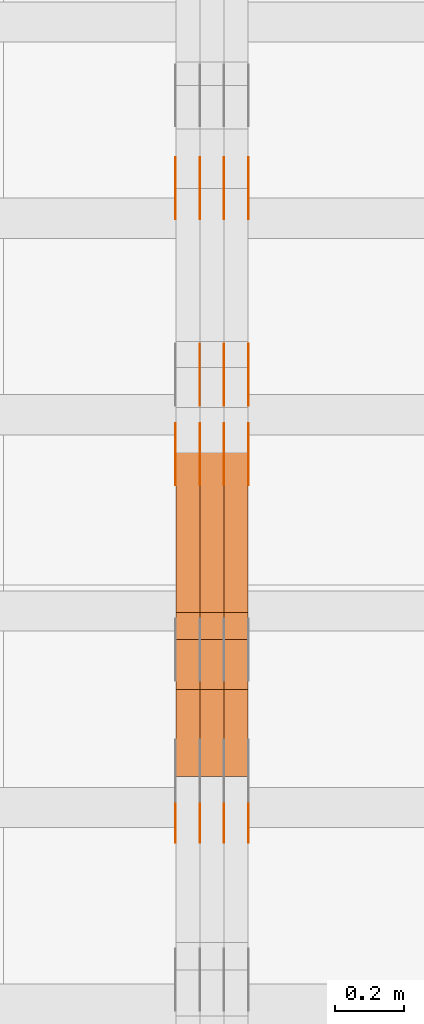
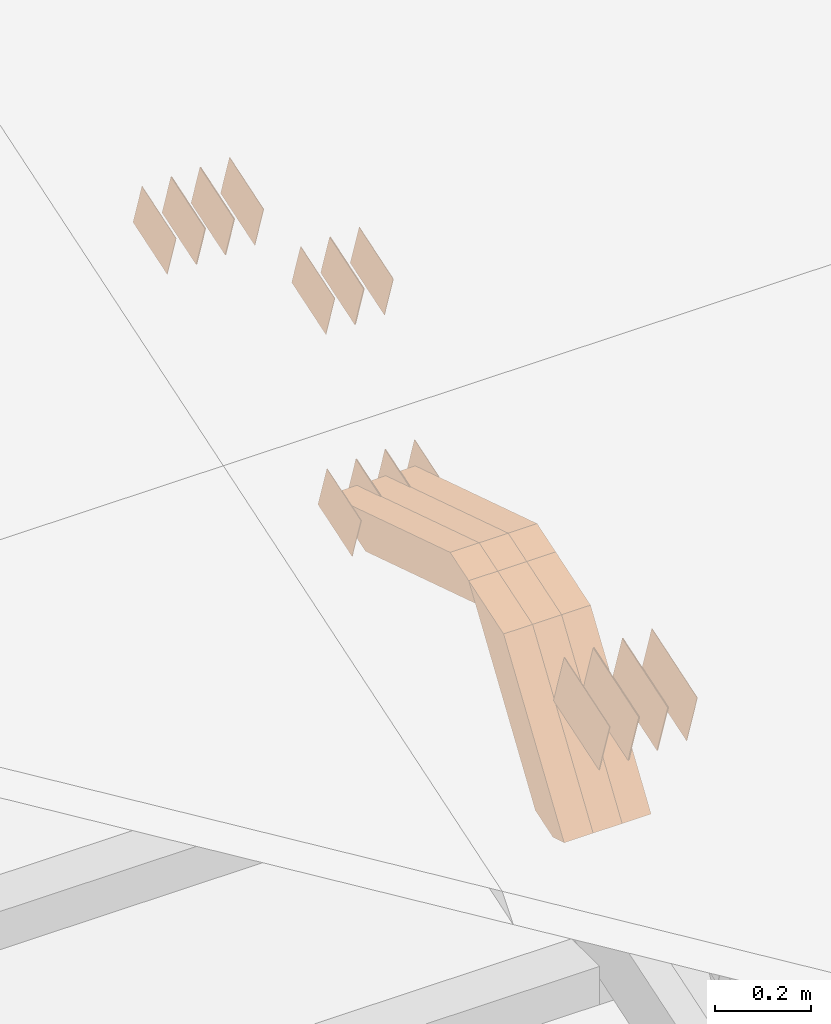
# One storey, part 110 of 385: 28 proxies.
"""IFC2X3 building model written with IfcOpenShell, lengths in millimetres."""

import ifcopenshell
import ifcopenshell.guid

model = None  # the IFC model being written
_history = None  # IfcOwnerHistory: only IFC2X3 demands one
_inside = {}  # id of a spatial element -> (the spatial element, [elements in it])
_under = {}  # id of a project, library or spatial element -> (it, [spatial elements below it])
_declared = {}  # id of a project -> (the project, [libraries it declares])
_typed = {}  # id of a type object -> (the type object, [elements of that type])
_made_of = {}  # id of a material, layer set ... -> (it, [elements and type objects made of it])


def new_model(schema):
    """Start an empty IFC model of exactly this schema.

    Asked for "IFC4X3", IfcOpenShell would pick the latest addendum, in which some entities
    have other attributes; the version numbers below select the first issue.
    IFC2X3 requires an IfcOwnerHistory on every rooted entity: one is made here for all.
    """
    global model, _history
    if schema == "IFC4X3":
        model = ifcopenshell.file(schema_version=(4, 3, 0, 0))
    else:
        model = ifcopenshell.file(schema=schema)
    _inside.clear()
    _under.clear()
    _declared.clear()
    _typed.clear()
    _made_of.clear()
    _history = None
    if model.schema == "IFC2X3":
        org = make("IfcOrganization", Name="unknown")
        user = make(
            "IfcPersonAndOrganization",
            ThePerson=make("IfcPerson", FamilyName="unknown"),
            TheOrganization=org,
        )
        app = make(
            "IfcApplication",
            ApplicationDeveloper=org,
            Version="unknown",
            ApplicationFullName="unknown",
            ApplicationIdentifier="unknown",
        )
        _history = make(
            "IfcOwnerHistory",
            OwningUser=user,
            OwningApplication=app,
            ChangeAction="ADDED",
            CreationDate=0,
        )
    return model


def make(cls, **values):
    """One entity of the class cls with the attributes given. An attribute that is None is left unset."""
    return model.create_entity(
        cls, **{name: value for name, value in values.items() if value is not None}
    )


def entity(cls, *values):
    """Any entity or typed value of the class cls, its attributes in the order of the schema. None: left unset."""
    e = model.create_entity(cls)
    for i, value in enumerate(values):
        if value is not None:
            e[i] = value
    return e


def rooted(cls, **values):
    """An entity with a GlobalId (a new one), such as an element, a storey or a relation."""
    return make(cls, GlobalId=ifcopenshell.guid.new(), OwnerHistory=_history, **values)


def si_unit(unit_type, name, prefix=None):
    """IfcSIUnit, for example si_unit("LENGTHUNIT", "METRE", prefix="MILLI")."""
    return make("IfcSIUnit", UnitType=unit_type, Prefix=prefix, Name=name)


def converted_unit(unit_type, name, factor, base, dimensions=None, offset=None):
    """IfcConversionBasedUnit, such as the inch: factor (a typed value) times the base unit."""
    return make(
        "IfcConversionBasedUnit"
        if offset is None
        else "IfcConversionBasedUnitWithOffset",
        ConversionOffset=offset,
        Dimensions=None
        if dimensions is None
        else entity("IfcDimensionalExponents", *dimensions),
        UnitType=unit_type,
        Name=name,
        ConversionFactor=make(
            "IfcMeasureWithUnit", ValueComponent=factor, UnitComponent=base
        ),
    )


def derived_unit(unit_type, elements):
    """IfcDerivedUnit: a product of units, each with its exponent."""
    return make(
        "IfcDerivedUnit",
        Elements=[
            make("IfcDerivedUnitElement", Unit=unit, Exponent=power)
            for unit, power in elements
        ],
        UnitType=unit_type,
    )


def assignment(units):
    """IfcUnitAssignment: the units of a project."""
    return None if units is None else make("IfcUnitAssignment", Units=units)


def point(xyz):
    """IfcCartesianPoint."""
    return None if xyz is None else make("IfcCartesianPoint", Coordinates=xyz)


def direction(xyz):
    """IfcDirection."""
    return None if xyz is None else make("IfcDirection", DirectionRatios=xyz)


def frame(location, z_axis=None, x_axis=None):
    """IfcAxis2Placement3D, a coordinate frame: its origin and axes. An axis left out is left unset."""
    return make(
        "IfcAxis2Placement3D",
        Location=point(location),
        Axis=direction(z_axis),
        RefDirection=direction(x_axis),
    )


def origin():
    """The frame at (0, 0, 0) with its axes left unset."""
    return frame((0.0, 0.0, 0.0))


def place(relative_to, where):
    """IfcLocalPlacement: puts the frame where relative to a parent placement (None: the world)."""
    return make(
        "IfcLocalPlacement", PlacementRelTo=relative_to, RelativePlacement=where
    )


def context(
    kind, dimensions, precision=None, world=None, true_north=None, identifier=None
):
    """IfcGeometricRepresentationContext, for example the 3D "Model" context."""
    return make(
        "IfcGeometricRepresentationContext",
        ContextIdentifier=identifier,
        ContextType=kind,
        CoordinateSpaceDimension=dimensions,
        Precision=precision,
        WorldCoordinateSystem=world,
        TrueNorth=true_north,
    )


def subcontext(parent, identifier, kind, view, scale=None):
    """IfcGeometricRepresentationSubContext, for example "Body" below "Model"."""
    return make(
        "IfcGeometricRepresentationSubContext",
        ContextIdentifier=identifier,
        ContextType=kind,
        ParentContext=parent,
        TargetScale=scale,
        TargetView=view,
    )


def project(units=None, contexts=None):
    """IfcProject with its units and contexts."""
    return rooted(
        "IfcProject",
        Name="project",
        RepresentationContexts=contexts,
        UnitsInContext=assignment(units),
    )


def spatial(cls, under=None, at=None, **own):
    """A site, building, storey or space (cls), placed at a placement, below another one or the project."""
    s = rooted(cls, ObjectPlacement=at, **own)
    if under is not None:
        _under.setdefault(under.id(), (under, []))[1].append(s)
    return s


def polyline(points):
    """IfcPolyline through the points."""
    return make("IfcPolyline", Points=[point(p) for p in points])


def outline(outer, holes=None, kind="AREA"):
    """IfcArbitraryClosedProfileDef: a profile drawn as a closed curve; with holes, ...WithVoids."""
    if holes is None:
        return make("IfcArbitraryClosedProfileDef", ProfileType=kind, OuterCurve=outer)
    return make(
        "IfcArbitraryProfileDefWithVoids",
        ProfileType=kind,
        OuterCurve=outer,
        InnerCurves=holes,
    )


def extrude(swept, where, along, depth):
    """IfcExtrudedAreaSolid: the profile swept, set in the frame where, extruded along a direction by depth."""
    return make(
        "IfcExtrudedAreaSolid",
        SweptArea=swept,
        Position=where,
        ExtrudedDirection=direction(along),
        Depth=depth,
    )


def shape(context_of_items, identifier, shape_type, items):
    """IfcShapeRepresentation: the items that make up one representation, for example the "Body"."""
    return make(
        "IfcShapeRepresentation",
        ContextOfItems=context_of_items,
        RepresentationIdentifier=identifier,
        RepresentationType=shape_type,
        Items=items,
    )


def source(mapping_origin, context_of_items, identifier, shape_type, items):
    """IfcRepresentationMap: a shape defined once, which mapped items show again and again."""
    return make(
        "IfcRepresentationMap",
        MappingOrigin=mapping_origin,
        MappedRepresentation=shape(context_of_items, identifier, shape_type, items),
    )


def transform(
    local_origin,
    x_axis=None,
    y_axis=None,
    z_axis=None,
    scale=None,
    scale2=None,
    scale3=None,
    uniform=True,
):
    """IfcCartesianTransformationOperator3D, or its non-uniform kind. x_axis, y_axis, z_axis: its Axis1, 2, 3."""
    if uniform:
        return make(
            "IfcCartesianTransformationOperator3D",
            Axis1=direction(x_axis),
            Axis2=direction(y_axis),
            LocalOrigin=point(local_origin),
            Scale=scale,
            Axis3=direction(z_axis),
        )
    return make(
        "IfcCartesianTransformationOperator3DnonUniform",
        Axis1=direction(x_axis),
        Axis2=direction(y_axis),
        LocalOrigin=point(local_origin),
        Scale=scale,
        Axis3=direction(z_axis),
        Scale2=scale2,
        Scale3=scale3,
    )


def mapped(mapping_source, mapping_target):
    """IfcMappedItem: shows the shape of a source again, moved by a transform."""
    return make(
        "IfcMappedItem", MappingSource=mapping_source, MappingTarget=mapping_target
    )


def material(Name=None, Category=None):
    """IfcMaterial."""
    return make("IfcMaterial", Name=Name, Category=Category)


def made_of(thing, what):
    """Note that an element or type object is made of a material, layer set ...; save() writes the relation."""
    if what is not None:
        _made_of.setdefault(what.id(), (what, []))[1].append(thing)
    return thing


def type_object(cls, material=None, **own):
    """A type object (cls), such as IfcWallType, which elements share."""
    return made_of(rooted(cls, **own), material)


def type_shapes(of_type, sources):
    """Give a type object the sources (RepresentationMaps) that its elements show as mapped items."""
    of_type.RepresentationMaps = sources


def element(
    cls,
    number,
    at=None,
    inside=None,
    cuts=None,
    type_object=None,
    material=None,
    context=None,
    identifier="Body",
    shape_type=None,
    held_by="IfcProductDefinitionShape",
    body=None,
    shapes=None,
    **own,
):
    """One element of the class cls, such as IfcWall. Its Tag is "e" and its number.

    at: its placement. inside: the storey or other place that contains it. cuts: it is an
    opening in that element (IfcRelVoidsElement). A single representation is given by context,
    identifier, shape_type and body (its items); several are given by shapes. held_by: the class
    of the entity that holds the representations. save() writes the other relations.
    """
    e = rooted(cls, Tag="e%d" % number, ObjectPlacement=at, **own)
    if body is not None:
        shapes = [shape(context, identifier, shape_type, body)]
    if shapes is not None:
        e.Representation = make(held_by, Representations=shapes)
    if inside is not None:
        _inside.setdefault(inside.id(), (inside, []))[1].append(e)
    if cuts is not None:
        rooted(
            "IfcRelVoidsElement", RelatingBuildingElement=cuts, RelatedOpeningElement=e
        )
    if type_object is not None:
        _typed.setdefault(type_object.id(), (type_object, []))[1].append(e)
    return made_of(e, material)


def aggregate(whole, parts):
    """IfcRelAggregates: a whole, such as a stair, and the parts it consists of."""
    return rooted("IfcRelAggregates", RelatingObject=whole, RelatedObjects=parts)


def save(model, path):
    """Write the relations noted so far, then the file.

    IfcRelAggregates (storeys below a building ...), IfcRelContainedInSpatialStructure (elements
    in a storey), IfcRelDefinesByType, IfcRelAssociatesMaterial and IfcRelDeclares: one each for
    every whole, place, type object, material and project.
    """
    for whole, parts in _under.values():
        aggregate(whole, parts)
    for where, things in _inside.values():
        rooted(
            "IfcRelContainedInSpatialStructure",
            RelatedElements=things,
            RelatingStructure=where,
        )
    for kind, things in _typed.values():
        rooted("IfcRelDefinesByType", RelatedObjects=things, RelatingType=kind)
    for what, things in _made_of.values():
        rooted("IfcRelAssociatesMaterial", RelatedObjects=things, RelatingMaterial=what)
    for by, libraries in _declared.values():
        rooted("IfcRelDeclares", RelatingContext=by, RelatedDefinitions=libraries)
    model.write(path)


model = new_model("IFC2X3")

# Units and contexts
model_context = context("Model", 3, precision=0.01, world=origin(), true_north=direction((6.12303176911189e-17, 1.0)))
body_context = subcontext(model_context, "Body", "Model", "MODEL_VIEW")
ifc_project = project(units=[si_unit("LENGTHUNIT", "METRE", prefix="MILLI"), si_unit("AREAUNIT", "SQUARE_METRE"), si_unit("VOLUMEUNIT", "CUBIC_METRE"), converted_unit("PLANEANGLEUNIT", "DEGREE", entity("IfcRatioMeasure", 0.0174532925199433), si_unit("PLANEANGLEUNIT", "RADIAN"), dimensions=[0, 0, 0, 0, 0, 0, 0]), si_unit("MASSUNIT", "GRAM", prefix="KILO"), derived_unit("MASSDENSITYUNIT", [(si_unit("MASSUNIT", "GRAM", prefix="KILO"), 1), (si_unit("LENGTHUNIT", "METRE"), -3)]), si_unit("TIMEUNIT", "SECOND"), si_unit("FREQUENCYUNIT", "HERTZ"), si_unit("THERMODYNAMICTEMPERATUREUNIT", "DEGREE_CELSIUS"), derived_unit("THERMALTRANSMITTANCEUNIT", [(si_unit("MASSUNIT", "GRAM", prefix="KILO"), 1), (si_unit("THERMODYNAMICTEMPERATUREUNIT", "KELVIN"), -1), (si_unit("TIMEUNIT", "SECOND"), -3)]), derived_unit("VOLUMETRICFLOWRATEUNIT", [(si_unit("LENGTHUNIT", "METRE"), 3), (si_unit("TIMEUNIT", "SECOND"), -1)]), si_unit("ELECTRICCURRENTUNIT", "AMPERE"), si_unit("ELECTRICVOLTAGEUNIT", "VOLT"), si_unit("POWERUNIT", "WATT"), si_unit("FORCEUNIT", "NEWTON", prefix="KILO"), si_unit("ILLUMINANCEUNIT", "LUX"), si_unit("LUMINOUSFLUXUNIT", "LUMEN"), si_unit("LUMINOUSINTENSITYUNIT", "CANDELA"), derived_unit("USERDEFINED", [(si_unit("MASSUNIT", "GRAM", prefix="KILO"), -1), (si_unit("LENGTHUNIT", "METRE"), -2), (si_unit("TIMEUNIT", "SECOND"), 3), (si_unit("LUMINOUSFLUXUNIT", "LUMEN"), 1)]), derived_unit("LINEARVELOCITYUNIT", [(si_unit("LENGTHUNIT", "METRE"), 1), (si_unit("TIMEUNIT", "SECOND"), -1)]), si_unit("PRESSUREUNIT", "PASCAL"), derived_unit("USERDEFINED", [(si_unit("LENGTHUNIT", "METRE"), -2), (si_unit("MASSUNIT", "GRAM", prefix="KILO"), 1), (si_unit("TIMEUNIT", "SECOND"), -2)])], contexts=[model_context])

# Site, building, storey
site_placement = place(None, origin())
site = spatial("IfcSite", under=ifc_project, at=site_placement, CompositionType="ELEMENT")
building_placement = place(site_placement, origin())
building = spatial("IfcBuilding", under=site, at=building_placement, CompositionType="ELEMENT")
storey_placement = place(building_placement, origin())
storey = spatial("IfcBuildingStorey", under=building, at=storey_placement, Name="Default", CompositionType="ELEMENT", Elevation=0.0)

# Proxies
ifc_material_1 = material(Name="IfcSurfaceStyle #241862")
building_element_proxy_type_1 = type_object("IfcBuildingElementProxyType", PredefinedType="NOTDEFINED", material=ifc_material_1)
shared_shape_1 = source(origin(), body_context, "Body", "SweptSolid", [
    extrude(outline(polyline([(-74.9998754286198, -60.0000016373433), (74.9998605591145, -60.0000016373433), (74.999875428618, 60.0000016373433), (-74.9998605591127, 60.0000016373433), (-74.9998754286198, -60.0000016373433)])), frame((75.0007059026038, 60.000210935219, 0.0), z_axis=(0.0, 0.0, 1.0), x_axis=(-1.0, 0.0, 0.0)), (0.0, 0.0, 1.0), 1.3),
])
type_shapes(building_element_proxy_type_1, [shared_shape_1])
proxy_1_placement = place(building_placement, frame((18386.3, 6760.15341914203, 1372.60670336718), z_axis=(-1.0, 0.0, 0.0), x_axis=(0.0, 0.951056516295124, 0.309016994375039)))
element("IfcBuildingElementProxy", 1, at=proxy_1_placement, inside=storey, type_object=building_element_proxy_type_1, material=ifc_material_1, context=body_context, shape_type="MappedRepresentation", body=[
    mapped(shared_shape_1, transform((0.0, 0.0, 0.0), scale=1.0)),
])
ifc_material_2 = material(Name="IfcSurfaceStyle #241805")
building_element_proxy_type_2 = type_object("IfcBuildingElementProxyType", PredefinedType="NOTDEFINED", material=ifc_material_2)
shared_shape_2 = source(origin(), body_context, "Body", "SweptSolid", [
    extrude(outline(polyline([(-74.9998754286198, -60.0000016373433), (74.9998605591145, -60.0000016373433), (74.999875428618, 60.0000016373433), (-74.9998605591127, 60.0000016373433), (-74.9998754286198, -60.0000016373433)])), frame((75.0007059026038, 60.000210935219, 0.0), z_axis=(0.0, 0.0, 1.0), x_axis=(-1.0, 0.0, 0.0)), (0.0, 0.0, 1.0), 1.3),
])
type_shapes(building_element_proxy_type_2, [shared_shape_2])
proxy_2_placement = place(building_placement, frame((18315.0, 6760.15341914203, 1372.60670336718), z_axis=(-1.0, 0.0, 0.0), x_axis=(0.0, 0.951056516295124, 0.309016994375039)))
element("IfcBuildingElementProxy", 2, at=proxy_2_placement, inside=storey, type_object=building_element_proxy_type_2, material=ifc_material_2, context=body_context, shape_type="MappedRepresentation", body=[
    mapped(shared_shape_2, transform((0.0, 0.0, 0.0), scale=1.0)),
])
ifc_material_3 = material(Name="IfcSurfaceStyle #241748")
building_element_proxy_type_3 = type_object("IfcBuildingElementProxyType", PredefinedType="NOTDEFINED", material=ifc_material_3)
shared_shape_3 = source(origin(), body_context, "Body", "SweptSolid", [
    extrude(outline(polyline([(-74.9998754286198, -60.0000016373433), (74.9998605591145, -60.0000016373433), (74.999875428618, 60.0000016373433), (-74.9998605591127, 60.0000016373433), (-74.9998754286198, -60.0000016373433)])), frame((75.0007059026038, 60.000210935219, 0.0), z_axis=(0.0, 0.0, 1.0), x_axis=(-1.0, 0.0, 0.0)), (0.0, 0.0, 1.0), 1.3),
])
type_shapes(building_element_proxy_type_3, [shared_shape_3])
proxy_3_placement = place(building_placement, frame((18316.3, 6760.15341914203, 1372.60670336718), z_axis=(-1.0, 0.0, 0.0), x_axis=(0.0, 0.951056516295124, 0.309016994375039)))
element("IfcBuildingElementProxy", 3, at=proxy_3_placement, inside=storey, type_object=building_element_proxy_type_3, material=ifc_material_3, context=body_context, shape_type="MappedRepresentation", body=[
    mapped(shared_shape_3, transform((0.0, 0.0, 0.0), scale=1.0)),
])
ifc_material_4 = material(Name="IfcSurfaceStyle #241691")
building_element_proxy_type_4 = type_object("IfcBuildingElementProxyType", PredefinedType="NOTDEFINED", material=ifc_material_4)
shared_shape_4 = source(origin(), body_context, "Body", "SweptSolid", [
    extrude(outline(polyline([(-74.9998754286198, -60.0000016373433), (74.9998605591145, -60.0000016373433), (74.999875428618, 60.0000016373433), (-74.9998605591127, 60.0000016373433), (-74.9998754286198, -60.0000016373433)])), frame((75.0007059026038, 60.000210935219, 0.0), z_axis=(0.0, 0.0, 1.0), x_axis=(-1.0, 0.0, 0.0)), (0.0, 0.0, 1.0), 1.29999999999999),
])
type_shapes(building_element_proxy_type_4, [shared_shape_4])
proxy_4_placement = place(building_placement, frame((18245.0, 6760.15341914203, 1372.60670336718), z_axis=(-1.0, 0.0, 0.0), x_axis=(0.0, 0.951056516295124, 0.309016994375039)))
element("IfcBuildingElementProxy", 4, at=proxy_4_placement, inside=storey, type_object=building_element_proxy_type_4, material=ifc_material_4, context=body_context, shape_type="MappedRepresentation", body=[
    mapped(shared_shape_4, transform((0.0, 0.0, 0.0), scale=1.0)),
])
ifc_material_5 = material(Name="IfcSurfaceStyle #241634")
building_element_proxy_type_5 = type_object("IfcBuildingElementProxyType", PredefinedType="NOTDEFINED", material=ifc_material_5)
shared_shape_5 = source(origin(), body_context, "Body", "SweptSolid", [
    extrude(outline(polyline([(-74.9998754286198, -60.0000016373433), (74.9998605591145, -60.0000016373433), (74.999875428618, 60.0000016373433), (-74.9998605591127, 60.0000016373433), (-74.9998754286198, -60.0000016373433)])), frame((75.0007059026038, 60.000210935219, 0.0), z_axis=(0.0, 0.0, 1.0), x_axis=(-1.0, 0.0, 0.0)), (0.0, 0.0, 1.0), 1.29999999999999),
])
type_shapes(building_element_proxy_type_5, [shared_shape_5])
proxy_5_placement = place(building_placement, frame((18246.3, 6760.15341914203, 1372.60670336718), z_axis=(-1.0, 0.0, 0.0), x_axis=(0.0, 0.951056516295124, 0.309016994375039)))
element("IfcBuildingElementProxy", 5, at=proxy_5_placement, inside=storey, type_object=building_element_proxy_type_5, material=ifc_material_5, context=body_context, shape_type="MappedRepresentation", body=[
    mapped(shared_shape_5, transform((0.0, 0.0, 0.0), scale=1.0)),
])
ifc_material_6 = material(Name="IfcSurfaceStyle #241577")
building_element_proxy_type_6 = type_object("IfcBuildingElementProxyType", PredefinedType="NOTDEFINED", material=ifc_material_6)
shared_shape_6 = source(origin(), body_context, "Body", "SweptSolid", [
    extrude(outline(polyline([(-74.9998754286198, -60.0000016373433), (74.9998605591145, -60.0000016373433), (74.999875428618, 60.0000016373433), (-74.9998605591127, 60.0000016373433), (-74.9998754286198, -60.0000016373433)])), frame((75.0007059026038, 60.000210935219, 0.0), z_axis=(0.0, 0.0, 1.0), x_axis=(-1.0, 0.0, 0.0)), (0.0, 0.0, 1.0), 1.29999999999999),
])
type_shapes(building_element_proxy_type_6, [shared_shape_6])
proxy_6_placement = place(building_placement, frame((18175.0, 6760.15341914203, 1372.60670336718), z_axis=(-1.0, 0.0, 0.0), x_axis=(0.0, 0.951056516295124, 0.309016994375039)))
element("IfcBuildingElementProxy", 6, at=proxy_6_placement, inside=storey, type_object=building_element_proxy_type_6, material=ifc_material_6, context=body_context, shape_type="MappedRepresentation", body=[
    mapped(shared_shape_6, transform((0.0, 0.0, 0.0), scale=1.0)),
])
ifc_material_7 = material(Name="IfcSurfaceStyle #235706")
building_element_proxy_type_7 = type_object("IfcBuildingElementProxyType", PredefinedType="NOTDEFINED", material=ifc_material_7)
shared_shape_7 = source(origin(), body_context, "Body", "SweptSolid", [
    extrude(outline(polyline([(-74.9998801438441, -60.0000306612856), (74.9998747047876, -60.0000306612856), (74.9998707133936, 60.0000306612856), (-74.9998652743371, 60.0000306612856), (-74.9998801438441, -60.0000306612856)])), frame((75.0000206139493, 60.0000306612856, 0.0), z_axis=(0.0, 0.0, 1.0), x_axis=(-1.0, 0.0, 0.0)), (0.0, 0.0, 1.0), 1.3),
])
type_shapes(building_element_proxy_type_7, [shared_shape_7])
proxy_7_placement = place(building_placement, frame((18386.3, 5987.08381858242, 1121.42116774683), z_axis=(-1.0, 0.0, 0.0), x_axis=(0.0, 0.951056516295124, 0.309016994375039)))
element("IfcBuildingElementProxy", 7, at=proxy_7_placement, inside=storey, type_object=building_element_proxy_type_7, material=ifc_material_7, context=body_context, shape_type="MappedRepresentation", body=[
    mapped(shared_shape_7, transform((0.0, 0.0, 0.0), scale=1.0)),
])
ifc_material_8 = material(Name="IfcSurfaceStyle #235649")
building_element_proxy_type_8 = type_object("IfcBuildingElementProxyType", PredefinedType="NOTDEFINED", material=ifc_material_8)
shared_shape_8 = source(origin(), body_context, "Body", "SweptSolid", [
    extrude(outline(polyline([(-74.9998801438441, -60.0000306612856), (74.9998747047876, -60.0000306612856), (74.9998707133936, 60.0000306612856), (-74.9998652743371, 60.0000306612856), (-74.9998801438441, -60.0000306612856)])), frame((75.0000206139493, 60.0000306612856, 0.0), z_axis=(0.0, 0.0, 1.0), x_axis=(-1.0, 0.0, 0.0)), (0.0, 0.0, 1.0), 1.3),
])
type_shapes(building_element_proxy_type_8, [shared_shape_8])
proxy_8_placement = place(building_placement, frame((18315.0, 5987.08381858242, 1121.42116774683), z_axis=(-1.0, 0.0, 0.0), x_axis=(0.0, 0.951056516295124, 0.309016994375039)))
element("IfcBuildingElementProxy", 8, at=proxy_8_placement, inside=storey, type_object=building_element_proxy_type_8, material=ifc_material_8, context=body_context, shape_type="MappedRepresentation", body=[
    mapped(shared_shape_8, transform((0.0, 0.0, 0.0), scale=1.0)),
])
ifc_material_9 = material(Name="IfcSurfaceStyle #235592")
building_element_proxy_type_9 = type_object("IfcBuildingElementProxyType", PredefinedType="NOTDEFINED", material=ifc_material_9)
shared_shape_9 = source(origin(), body_context, "Body", "SweptSolid", [
    extrude(outline(polyline([(-74.9998801438441, -60.0000306612856), (74.9998747047876, -60.0000306612856), (74.9998707133936, 60.0000306612856), (-74.9998652743371, 60.0000306612856), (-74.9998801438441, -60.0000306612856)])), frame((75.0000206139493, 60.0000306612856, 0.0), z_axis=(0.0, 0.0, 1.0), x_axis=(-1.0, 0.0, 0.0)), (0.0, 0.0, 1.0), 1.3),
])
type_shapes(building_element_proxy_type_9, [shared_shape_9])
proxy_9_placement = place(building_placement, frame((18316.3, 5987.08381858242, 1121.42116774683), z_axis=(-1.0, 0.0, 0.0), x_axis=(0.0, 0.951056516295124, 0.309016994375039)))
element("IfcBuildingElementProxy", 9, at=proxy_9_placement, inside=storey, type_object=building_element_proxy_type_9, material=ifc_material_9, context=body_context, shape_type="MappedRepresentation", body=[
    mapped(shared_shape_9, transform((0.0, 0.0, 0.0), scale=1.0)),
])
ifc_material_10 = material(Name="IfcSurfaceStyle #235535")
building_element_proxy_type_10 = type_object("IfcBuildingElementProxyType", PredefinedType="NOTDEFINED", material=ifc_material_10)
shared_shape_10 = source(origin(), body_context, "Body", "SweptSolid", [
    extrude(outline(polyline([(-74.9998801438441, -60.0000306612856), (74.9998747047876, -60.0000306612856), (74.9998707133936, 60.0000306612856), (-74.9998652743371, 60.0000306612856), (-74.9998801438441, -60.0000306612856)])), frame((75.0000206139493, 60.0000306612856, 0.0), z_axis=(0.0, 0.0, 1.0), x_axis=(-1.0, 0.0, 0.0)), (0.0, 0.0, 1.0), 1.29999999999999),
])
type_shapes(building_element_proxy_type_10, [shared_shape_10])
proxy_10_placement = place(building_placement, frame((18245.0, 5987.08381858242, 1121.42116774683), z_axis=(-1.0, 0.0, 0.0), x_axis=(0.0, 0.951056516295124, 0.309016994375039)))
element("IfcBuildingElementProxy", 10, at=proxy_10_placement, inside=storey, type_object=building_element_proxy_type_10, material=ifc_material_10, context=body_context, shape_type="MappedRepresentation", body=[
    mapped(shared_shape_10, transform((0.0, 0.0, 0.0), scale=1.0)),
])
ifc_material_11 = material(Name="IfcSurfaceStyle #235478")
building_element_proxy_type_11 = type_object("IfcBuildingElementProxyType", PredefinedType="NOTDEFINED", material=ifc_material_11)
shared_shape_11 = source(origin(), body_context, "Body", "SweptSolid", [
    extrude(outline(polyline([(-74.9998801438441, -60.0000306612856), (74.9998747047876, -60.0000306612856), (74.9998707133936, 60.0000306612856), (-74.9998652743371, 60.0000306612856), (-74.9998801438441, -60.0000306612856)])), frame((75.0000206139493, 60.0000306612856, 0.0), z_axis=(0.0, 0.0, 1.0), x_axis=(-1.0, 0.0, 0.0)), (0.0, 0.0, 1.0), 1.29999999999999),
])
type_shapes(building_element_proxy_type_11, [shared_shape_11])
proxy_11_placement = place(building_placement, frame((18246.3, 5987.08381858242, 1121.42116774683), z_axis=(-1.0, 0.0, 0.0), x_axis=(0.0, 0.951056516295124, 0.309016994375039)))
element("IfcBuildingElementProxy", 11, at=proxy_11_placement, inside=storey, type_object=building_element_proxy_type_11, material=ifc_material_11, context=body_context, shape_type="MappedRepresentation", body=[
    mapped(shared_shape_11, transform((0.0, 0.0, 0.0), scale=1.0)),
])
ifc_material_12 = material(Name="IfcSurfaceStyle #235421")
building_element_proxy_type_12 = type_object("IfcBuildingElementProxyType", PredefinedType="NOTDEFINED", material=ifc_material_12)
shared_shape_12 = source(origin(), body_context, "Body", "SweptSolid", [
    extrude(outline(polyline([(-74.9998801438441, -60.0000306612856), (74.9998747047876, -60.0000306612856), (74.9998707133936, 60.0000306612856), (-74.9998652743371, 60.0000306612856), (-74.9998801438441, -60.0000306612856)])), frame((75.0000206139493, 60.0000306612856, 0.0), z_axis=(0.0, 0.0, 1.0), x_axis=(-1.0, 0.0, 0.0)), (0.0, 0.0, 1.0), 1.29999999999999),
])
type_shapes(building_element_proxy_type_12, [shared_shape_12])
proxy_12_placement = place(building_placement, frame((18175.0, 5987.08381858242, 1121.42116774683), z_axis=(-1.0, 0.0, 0.0), x_axis=(0.0, 0.951056516295124, 0.309016994375039)))
element("IfcBuildingElementProxy", 12, at=proxy_12_placement, inside=storey, type_object=building_element_proxy_type_12, material=ifc_material_12, context=body_context, shape_type="MappedRepresentation", body=[
    mapped(shared_shape_12, transform((0.0, 0.0, 0.0), scale=1.0)),
])
ifc_material_13 = material(Name="IfcSurfaceStyle #231260")
building_element_proxy_type_13 = type_object("IfcBuildingElementProxyType", PredefinedType="NOTDEFINED", material=ifc_material_13)
shared_shape_13 = source(origin(), body_context, "Body", "SweptSolid", [
    extrude(outline(polyline([(-74.9998754286253, -60.0000016373506), (74.999860559109, -60.0000016373506), (74.9998754286235, 60.0000016373506), (-74.9998605591072, 60.0000016373506), (-74.9998754286253, -60.0000016373506)])), frame((75.0001009411744, 60.0000279841752, 0.0), z_axis=(0.0, 0.0, 1.0), x_axis=(-1.0, 0.0, 0.0)), (0.0, 0.0, 1.0), 1.3),
])
type_shapes(building_element_proxy_type_13, [shared_shape_13])
proxy_13_placement = place(building_placement, frame((18386.3, 6218.29662915452, 1523.23574463408), z_axis=(-1.0, 0.0, 0.0), x_axis=(0.0, 0.951056516295154, 0.309016994374948)))
element("IfcBuildingElementProxy", 13, at=proxy_13_placement, inside=storey, type_object=building_element_proxy_type_13, material=ifc_material_13, context=body_context, shape_type="MappedRepresentation", body=[
    mapped(shared_shape_13, transform((0.0, 0.0, 0.0), scale=1.0)),
])
ifc_material_14 = material(Name="IfcSurfaceStyle #231203")
building_element_proxy_type_14 = type_object("IfcBuildingElementProxyType", PredefinedType="NOTDEFINED", material=ifc_material_14)
shared_shape_14 = source(origin(), body_context, "Body", "SweptSolid", [
    extrude(outline(polyline([(-74.9998754286253, -60.0000016373506), (74.999860559109, -60.0000016373506), (74.9998754286235, 60.0000016373506), (-74.9998605591072, 60.0000016373506), (-74.9998754286253, -60.0000016373506)])), frame((75.0001009411744, 60.0000279841752, 0.0), z_axis=(0.0, 0.0, 1.0), x_axis=(-1.0, 0.0, 0.0)), (0.0, 0.0, 1.0), 1.3),
])
type_shapes(building_element_proxy_type_14, [shared_shape_14])
proxy_14_placement = place(building_placement, frame((18315.0, 6218.29662915452, 1523.23574463408), z_axis=(-1.0, 0.0, 0.0), x_axis=(0.0, 0.951056516295154, 0.309016994374948)))
element("IfcBuildingElementProxy", 14, at=proxy_14_placement, inside=storey, type_object=building_element_proxy_type_14, material=ifc_material_14, context=body_context, shape_type="MappedRepresentation", body=[
    mapped(shared_shape_14, transform((0.0, 0.0, 0.0), scale=1.0)),
])
ifc_material_15 = material(Name="IfcSurfaceStyle #231146")
building_element_proxy_type_15 = type_object("IfcBuildingElementProxyType", PredefinedType="NOTDEFINED", material=ifc_material_15)
shared_shape_15 = source(origin(), body_context, "Body", "SweptSolid", [
    extrude(outline(polyline([(-74.9998754286253, -60.0000016373506), (74.999860559109, -60.0000016373506), (74.9998754286235, 60.0000016373506), (-74.9998605591072, 60.0000016373506), (-74.9998754286253, -60.0000016373506)])), frame((75.0001009411744, 60.0000279841752, 0.0), z_axis=(0.0, 0.0, 1.0), x_axis=(-1.0, 0.0, 0.0)), (0.0, 0.0, 1.0), 1.3),
])
type_shapes(building_element_proxy_type_15, [shared_shape_15])
proxy_15_placement = place(building_placement, frame((18316.3, 6218.29662915452, 1523.23574463408), z_axis=(-1.0, 0.0, 0.0), x_axis=(0.0, 0.951056516295154, 0.309016994374948)))
element("IfcBuildingElementProxy", 15, at=proxy_15_placement, inside=storey, type_object=building_element_proxy_type_15, material=ifc_material_15, context=body_context, shape_type="MappedRepresentation", body=[
    mapped(shared_shape_15, transform((0.0, 0.0, 0.0), scale=1.0)),
])
ifc_material_16 = material(Name="IfcSurfaceStyle #231089")
building_element_proxy_type_16 = type_object("IfcBuildingElementProxyType", PredefinedType="NOTDEFINED", material=ifc_material_16)
shared_shape_16 = source(origin(), body_context, "Body", "SweptSolid", [
    extrude(outline(polyline([(-74.9998754286253, -60.0000016373506), (74.999860559109, -60.0000016373506), (74.9998754286235, 60.0000016373506), (-74.9998605591072, 60.0000016373506), (-74.9998754286253, -60.0000016373506)])), frame((75.0001009411744, 60.0000279841752, 0.0), z_axis=(0.0, 0.0, 1.0), x_axis=(-1.0, 0.0, 0.0)), (0.0, 0.0, 1.0), 1.29999999999999),
])
type_shapes(building_element_proxy_type_16, [shared_shape_16])
proxy_16_placement = place(building_placement, frame((18245.0, 6218.29662915452, 1523.23574463408), z_axis=(-1.0, 0.0, 0.0), x_axis=(0.0, 0.951056516295154, 0.309016994374948)))
element("IfcBuildingElementProxy", 16, at=proxy_16_placement, inside=storey, type_object=building_element_proxy_type_16, material=ifc_material_16, context=body_context, shape_type="MappedRepresentation", body=[
    mapped(shared_shape_16, transform((0.0, 0.0, 0.0), scale=1.0)),
])
ifc_material_17 = material(Name="IfcSurfaceStyle #226814")
building_element_proxy_type_17 = type_object("IfcBuildingElementProxyType", PredefinedType="NOTDEFINED", material=ifc_material_17)
shared_shape_17 = source(origin(), body_context, "Body", "SweptSolid", [
    extrude(outline(polyline([(-99.9996257846169, -71.999973710258), (100.000009625089, -71.999973710258), (99.9996257846187, 71.999973710258), (-100.000009625091, 71.999973710258), (-99.9996257846169, -71.999973710258)])), frame((100.000083496635, 72.0000008245779, 0.0), z_axis=(0.0, 0.0, 1.0), x_axis=(-1.0, 0.0, 0.0)), (0.0, 0.0, 1.0), 1.3),
])
type_shapes(building_element_proxy_type_17, [shared_shape_17])
proxy_17_placement = place(building_placement, frame((18386.3, 4947.73195917316, 1225.53937157357), z_axis=(-1.0, 0.0, 0.0), x_axis=(0.0, 0.951056516295154, 0.309016994374948)))
element("IfcBuildingElementProxy", 17, at=proxy_17_placement, inside=storey, type_object=building_element_proxy_type_17, material=ifc_material_17, context=body_context, shape_type="MappedRepresentation", body=[
    mapped(shared_shape_17, transform((0.0, 0.0, 0.0), scale=1.0)),
])
ifc_material_18 = material(Name="IfcSurfaceStyle #226757")
building_element_proxy_type_18 = type_object("IfcBuildingElementProxyType", PredefinedType="NOTDEFINED", material=ifc_material_18)
shared_shape_18 = source(origin(), body_context, "Body", "SweptSolid", [
    extrude(outline(polyline([(-99.9996257846169, -71.999973710258), (100.000009625089, -71.999973710258), (99.9996257846187, 71.999973710258), (-100.000009625091, 71.999973710258), (-99.9996257846169, -71.999973710258)])), frame((100.000083496635, 72.0000008245779, 0.0), z_axis=(0.0, 0.0, 1.0), x_axis=(-1.0, 0.0, 0.0)), (0.0, 0.0, 1.0), 1.3),
])
type_shapes(building_element_proxy_type_18, [shared_shape_18])
proxy_18_placement = place(building_placement, frame((18315.0, 4947.73195917316, 1225.53937157357), z_axis=(-1.0, 0.0, 0.0), x_axis=(0.0, 0.951056516295154, 0.309016994374948)))
element("IfcBuildingElementProxy", 18, at=proxy_18_placement, inside=storey, type_object=building_element_proxy_type_18, material=ifc_material_18, context=body_context, shape_type="MappedRepresentation", body=[
    mapped(shared_shape_18, transform((0.0, 0.0, 0.0), scale=1.0)),
])
ifc_material_19 = material(Name="IfcSurfaceStyle #226700")
building_element_proxy_type_19 = type_object("IfcBuildingElementProxyType", PredefinedType="NOTDEFINED", material=ifc_material_19)
shared_shape_19 = source(origin(), body_context, "Body", "SweptSolid", [
    extrude(outline(polyline([(-99.9996257846169, -71.999973710258), (100.000009625089, -71.999973710258), (99.9996257846187, 71.999973710258), (-100.000009625091, 71.999973710258), (-99.9996257846169, -71.999973710258)])), frame((100.000083496635, 72.0000008245779, 0.0), z_axis=(0.0, 0.0, 1.0), x_axis=(-1.0, 0.0, 0.0)), (0.0, 0.0, 1.0), 1.3),
])
type_shapes(building_element_proxy_type_19, [shared_shape_19])
proxy_19_placement = place(building_placement, frame((18316.3, 4947.73195917316, 1225.53937157357), z_axis=(-1.0, 0.0, 0.0), x_axis=(0.0, 0.951056516295154, 0.309016994374948)))
element("IfcBuildingElementProxy", 19, at=proxy_19_placement, inside=storey, type_object=building_element_proxy_type_19, material=ifc_material_19, context=body_context, shape_type="MappedRepresentation", body=[
    mapped(shared_shape_19, transform((0.0, 0.0, 0.0), scale=1.0)),
])
ifc_material_20 = material(Name="IfcSurfaceStyle #226643")
building_element_proxy_type_20 = type_object("IfcBuildingElementProxyType", PredefinedType="NOTDEFINED", material=ifc_material_20)
shared_shape_20 = source(origin(), body_context, "Body", "SweptSolid", [
    extrude(outline(polyline([(-99.9996257846169, -71.999973710258), (100.000009625089, -71.999973710258), (99.9996257846187, 71.999973710258), (-100.000009625091, 71.999973710258), (-99.9996257846169, -71.999973710258)])), frame((100.000083496635, 72.0000008245779, 0.0), z_axis=(0.0, 0.0, 1.0), x_axis=(-1.0, 0.0, 0.0)), (0.0, 0.0, 1.0), 1.29999999999998),
])
type_shapes(building_element_proxy_type_20, [shared_shape_20])
proxy_20_placement = place(building_placement, frame((18245.0, 4947.73195917316, 1225.53937157357), z_axis=(-1.0, 0.0, 0.0), x_axis=(0.0, 0.951056516295154, 0.309016994374948)))
element("IfcBuildingElementProxy", 20, at=proxy_20_placement, inside=storey, type_object=building_element_proxy_type_20, material=ifc_material_20, context=body_context, shape_type="MappedRepresentation", body=[
    mapped(shared_shape_20, transform((0.0, 0.0, 0.0), scale=1.0)),
])
ifc_material_21 = material(Name="IfcSurfaceStyle #226586")
building_element_proxy_type_21 = type_object("IfcBuildingElementProxyType", PredefinedType="NOTDEFINED", material=ifc_material_21)
shared_shape_21 = source(origin(), body_context, "Body", "SweptSolid", [
    extrude(outline(polyline([(-99.9996257846169, -71.999973710258), (100.000009625089, -71.999973710258), (99.9996257846187, 71.999973710258), (-100.000009625091, 71.999973710258), (-99.9996257846169, -71.999973710258)])), frame((100.000083496635, 72.0000008245779, 0.0), z_axis=(0.0, 0.0, 1.0), x_axis=(-1.0, 0.0, 0.0)), (0.0, 0.0, 1.0), 1.29999999999998),
])
type_shapes(building_element_proxy_type_21, [shared_shape_21])
proxy_21_placement = place(building_placement, frame((18246.3, 4947.73195917316, 1225.53937157357), z_axis=(-1.0, 0.0, 0.0), x_axis=(0.0, 0.951056516295154, 0.309016994374948)))
element("IfcBuildingElementProxy", 21, at=proxy_21_placement, inside=storey, type_object=building_element_proxy_type_21, material=ifc_material_21, context=body_context, shape_type="MappedRepresentation", body=[
    mapped(shared_shape_21, transform((0.0, 0.0, 0.0), scale=1.0)),
])
ifc_material_22 = material(Name="IfcSurfaceStyle #226529")
building_element_proxy_type_22 = type_object("IfcBuildingElementProxyType", PredefinedType="NOTDEFINED", material=ifc_material_22)
shared_shape_22 = source(origin(), body_context, "Body", "SweptSolid", [
    extrude(outline(polyline([(-99.9996257846169, -71.999973710258), (100.000009625089, -71.999973710258), (99.9996257846187, 71.999973710258), (-100.000009625091, 71.999973710258), (-99.9996257846169, -71.999973710258)])), frame((100.000083496635, 72.0000008245779, 0.0), z_axis=(0.0, 0.0, 1.0), x_axis=(-1.0, 0.0, 0.0)), (0.0, 0.0, 1.0), 1.29999999999999),
])
type_shapes(building_element_proxy_type_22, [shared_shape_22])
proxy_22_placement = place(building_placement, frame((18175.0, 4947.73195917316, 1225.53937157357), z_axis=(-1.0, 0.0, 0.0), x_axis=(0.0, 0.951056516295154, 0.309016994374948)))
element("IfcBuildingElementProxy", 22, at=proxy_22_placement, inside=storey, type_object=building_element_proxy_type_22, material=ifc_material_22, context=body_context, shape_type="MappedRepresentation", body=[
    mapped(shared_shape_22, transform((0.0, 0.0, 0.0), scale=1.0)),
])
ifc_material_23 = material(Name="IfcSurfaceStyle #217472")
building_element_proxy_type_23 = type_object("IfcBuildingElementProxyType", Name="T1-W15 217470", PredefinedType="NOTDEFINED", material=ifc_material_23)
shared_shape_23 = source(origin(), body_context, "Body", "SweptSolid", [
    extrude(outline(polyline([(-243.398341390642, -47.5000170814535), (237.775741169608, -47.5000170814535), (224.054017709933, 0.000127777485579883), (157.692261395711, 47.4999531927108), (-376.12367888461, 47.4999531927107), (-243.398341390642, -47.5000170814535)])), frame((237.77637044506, 47.5003404768297, 0.0), z_axis=(0.0, 0.0, 1.0), x_axis=(-1.0, 0.0, 0.0)), (0.0, 0.0, 1.0), 70.0),
])
type_shapes(building_element_proxy_type_23, [shared_shape_23])
proxy_23_placement = place(building_placement, frame((18385.0, 5540.23242178142, 1288.84274826279), z_axis=(-1.0, 0.0, 0.0), x_axis=(0.0, 0.95322291386448, -0.302268219440466)))
element("IfcBuildingElementProxy", 23, at=proxy_23_placement, inside=storey, type_object=building_element_proxy_type_23, material=ifc_material_23, Name="T1-W15", context=body_context, shape_type="MappedRepresentation", body=[
    mapped(shared_shape_23, transform((0.0, 0.0, 0.0), scale=1.0)),
])
ifc_material_24 = material(Name="IfcSurfaceStyle #217406")
building_element_proxy_type_24 = type_object("IfcBuildingElementProxyType", Name="T1-W15 217404", PredefinedType="NOTDEFINED", material=ifc_material_24)
shared_shape_24 = source(origin(), body_context, "Body", "SweptSolid", [
    extrude(outline(polyline([(-243.398341390642, -47.5000170814535), (237.775741169608, -47.5000170814535), (224.054017709933, 0.000127777485579883), (157.692261395711, 47.4999531927108), (-376.12367888461, 47.4999531927107), (-243.398341390642, -47.5000170814535)])), frame((237.77637044506, 47.5003404768297, 0.0), z_axis=(0.0, 0.0, 1.0), x_axis=(-1.0, 0.0, 0.0)), (0.0, 0.0, 1.0), 70.0),
])
type_shapes(building_element_proxy_type_24, [shared_shape_24])
proxy_24_placement = place(building_placement, frame((18315.0, 5540.23242178142, 1288.84274826279), z_axis=(-1.0, 0.0, 0.0), x_axis=(0.0, 0.95322291386448, -0.302268219440466)))
element("IfcBuildingElementProxy", 24, at=proxy_24_placement, inside=storey, type_object=building_element_proxy_type_24, material=ifc_material_24, Name="T1-W15", context=body_context, shape_type="MappedRepresentation", body=[
    mapped(shared_shape_24, transform((0.0, 0.0, 0.0), scale=1.0)),
])
ifc_material_25 = material(Name="IfcSurfaceStyle #217340")
building_element_proxy_type_25 = type_object("IfcBuildingElementProxyType", Name="T1-W15 217338", PredefinedType="NOTDEFINED", material=ifc_material_25)
shared_shape_25 = source(origin(), body_context, "Body", "SweptSolid", [
    extrude(outline(polyline([(-243.398341390642, -47.5000170814535), (237.775741169608, -47.5000170814535), (224.054017709933, 0.000127777485579883), (157.692261395711, 47.4999531927108), (-376.12367888461, 47.4999531927107), (-243.398341390642, -47.5000170814535)])), frame((237.77637044506, 47.5003404768297, 0.0), z_axis=(0.0, 0.0, 1.0), x_axis=(-1.0, 0.0, 0.0)), (0.0, 0.0, 1.0), 70.0),
])
type_shapes(building_element_proxy_type_25, [shared_shape_25])
proxy_25_placement = place(building_placement, frame((18245.0, 5540.23242178142, 1288.84274826279), z_axis=(-1.0, 0.0, 0.0), x_axis=(0.0, 0.95322291386448, -0.302268219440466)))
element("IfcBuildingElementProxy", 25, at=proxy_25_placement, inside=storey, type_object=building_element_proxy_type_25, material=ifc_material_25, Name="T1-W15", context=body_context, shape_type="MappedRepresentation", body=[
    mapped(shared_shape_25, transform((0.0, 0.0, 0.0), scale=1.0)),
])
ifc_material_26 = material(Name="IfcSurfaceStyle #217076")
building_element_proxy_type_26 = type_object("IfcBuildingElementProxyType", Name="T1-W22 217074", PredefinedType="NOTDEFINED", material=ifc_material_26)
shared_shape_26 = source(origin(), body_context, "Body", "SweptSolid", [
    extrude(outline(polyline([(-351.940486061686, -47.5005995570677), (149.451602529695, -47.5005995570676), (209.614029773051, 0.000108554198836676), (224.491670779786, 47.5010029530092), (-231.616817020846, 47.5000876069273), (-351.940486061686, -47.5005995570677)])), frame((224.491766107217, 47.5005524294596, 0.0), z_axis=(0.0, 0.0, 1.0), x_axis=(-1.0, 2.00686044286885e-06, 0.0)), (0.0, 0.0, 1.0), 70.0),
])
type_shapes(building_element_proxy_type_26, [shared_shape_26])
proxy_26_placement = place(building_placement, frame((18385.0, 5140.03125, 812.615600585936), z_axis=(-1.0, 0.0, 0.0), x_axis=(0.0, 0.554956576676696, 0.831879316970486)))
element("IfcBuildingElementProxy", 26, at=proxy_26_placement, inside=storey, type_object=building_element_proxy_type_26, material=ifc_material_26, Name="T1-W22", context=body_context, shape_type="MappedRepresentation", body=[
    mapped(shared_shape_26, transform((0.0, 0.0, 0.0), scale=1.0)),
])
ifc_material_27 = material(Name="IfcSurfaceStyle #217010")
building_element_proxy_type_27 = type_object("IfcBuildingElementProxyType", Name="T1-W22 217008", PredefinedType="NOTDEFINED", material=ifc_material_27)
shared_shape_27 = source(origin(), body_context, "Body", "SweptSolid", [
    extrude(outline(polyline([(-351.940486061686, -47.5005995570677), (149.451602529695, -47.5005995570676), (209.614029773051, 0.000108554198836676), (224.491670779786, 47.5010029530092), (-231.616817020846, 47.5000876069273), (-351.940486061686, -47.5005995570677)])), frame((224.491766107217, 47.5005524294596, 0.0), z_axis=(0.0, 0.0, 1.0), x_axis=(-1.0, 2.00686044286885e-06, 0.0)), (0.0, 0.0, 1.0), 70.0),
])
type_shapes(building_element_proxy_type_27, [shared_shape_27])
proxy_27_placement = place(building_placement, frame((18315.0, 5140.03125, 812.615600585936), z_axis=(-1.0, 0.0, 0.0), x_axis=(0.0, 0.554956576676696, 0.831879316970486)))
element("IfcBuildingElementProxy", 27, at=proxy_27_placement, inside=storey, type_object=building_element_proxy_type_27, material=ifc_material_27, Name="T1-W22", context=body_context, shape_type="MappedRepresentation", body=[
    mapped(shared_shape_27, transform((0.0, 0.0, 0.0), scale=1.0)),
])
ifc_material_28 = material(Name="IfcSurfaceStyle #216944")
building_element_proxy_type_28 = type_object("IfcBuildingElementProxyType", Name="T1-W22 216942", PredefinedType="NOTDEFINED", material=ifc_material_28)
shared_shape_28 = source(origin(), body_context, "Body", "SweptSolid", [
    extrude(outline(polyline([(-351.940486061686, -47.5005995570677), (149.451602529695, -47.5005995570676), (209.614029773051, 0.000108554198836676), (224.491670779786, 47.5010029530092), (-231.616817020846, 47.5000876069273), (-351.940486061686, -47.5005995570677)])), frame((224.491766107217, 47.5005524294596, 0.0), z_axis=(0.0, 0.0, 1.0), x_axis=(-1.0, 2.00686044286885e-06, 0.0)), (0.0, 0.0, 1.0), 70.0),
])
type_shapes(building_element_proxy_type_28, [shared_shape_28])
proxy_28_placement = place(building_placement, frame((18245.0, 5140.03125, 812.615600585936), z_axis=(-1.0, 0.0, 0.0), x_axis=(0.0, 0.554956576676696, 0.831879316970486)))
element("IfcBuildingElementProxy", 28, at=proxy_28_placement, inside=storey, type_object=building_element_proxy_type_28, material=ifc_material_28, Name="T1-W22", context=body_context, shape_type="MappedRepresentation", body=[
    mapped(shared_shape_28, transform((0.0, 0.0, 0.0), scale=1.0)),
])

save(model, "model.ifc")
